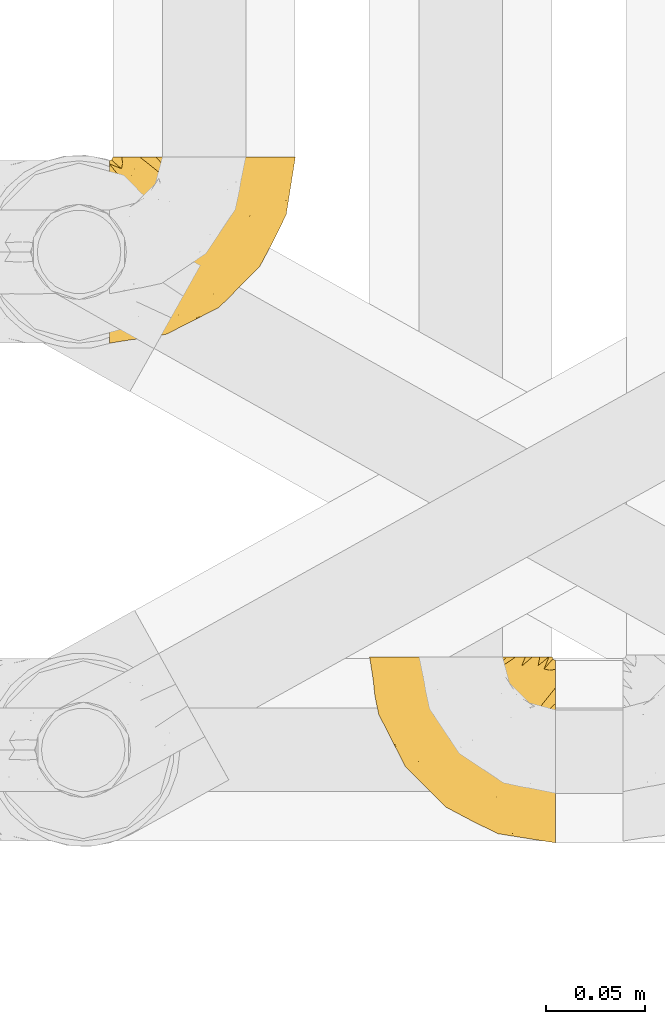
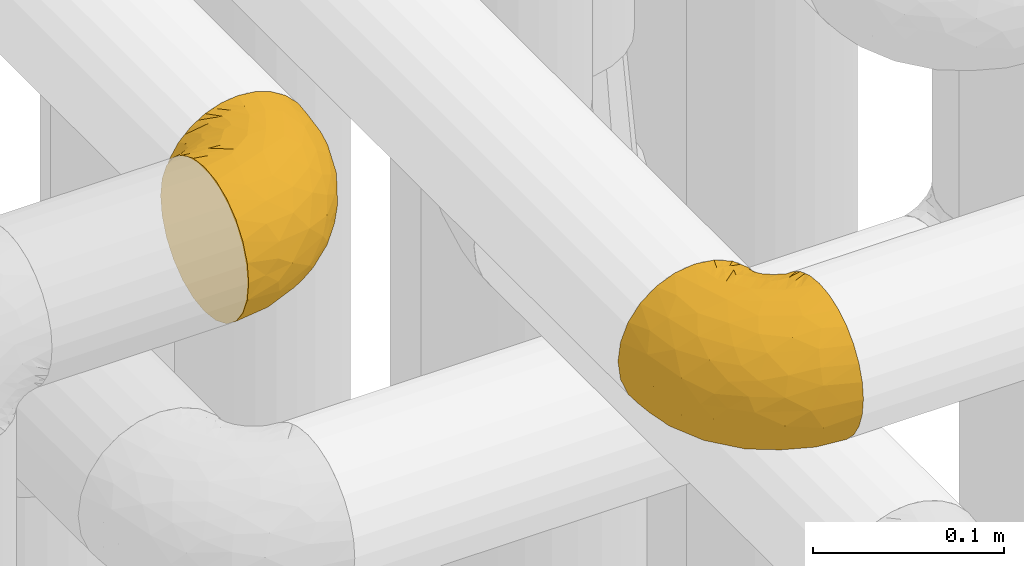
# One storey, part 154 of 827: 2 coverings.
"""IFC2X3 building model written with IfcOpenShell, lengths in millimetres."""

from ifc_helpers import new_model, entity, si_unit, converted_unit, derived_unit, direction, frame, origin, place, context, subcontext, project, spatial, faceted_brep, element, save


model = new_model("IFC2X3")

# Units and contexts
model_context = context("Model", 3, precision=0.01, world=origin(), true_north=direction((6.12303176911189e-17, 1.0)))
body_context = subcontext(model_context, "Body", "Model", "MODEL_VIEW")
ifc_project = project(units=[si_unit("LENGTHUNIT", "METRE", prefix="MILLI"), si_unit("AREAUNIT", "SQUARE_METRE"), si_unit("VOLUMEUNIT", "CUBIC_METRE"), converted_unit("PLANEANGLEUNIT", "DEGREE", entity("IfcRatioMeasure", 0.0174532925199433), si_unit("PLANEANGLEUNIT", "RADIAN"), dimensions=[0, 0, 0, 0, 0, 0, 0]), si_unit("MASSUNIT", "GRAM", prefix="KILO"), derived_unit("MASSDENSITYUNIT", [(si_unit("MASSUNIT", "GRAM", prefix="KILO"), 1), (si_unit("LENGTHUNIT", "METRE"), -3)]), derived_unit("MOMENTOFINERTIAUNIT", [(si_unit("LENGTHUNIT", "METRE"), 4)]), si_unit("TIMEUNIT", "SECOND"), si_unit("FREQUENCYUNIT", "HERTZ"), si_unit("THERMODYNAMICTEMPERATUREUNIT", "DEGREE_CELSIUS"), derived_unit("THERMALTRANSMITTANCEUNIT", [(si_unit("MASSUNIT", "GRAM", prefix="KILO"), 1), (si_unit("THERMODYNAMICTEMPERATUREUNIT", "KELVIN"), -1), (si_unit("TIMEUNIT", "SECOND"), -3)]), derived_unit("VOLUMETRICFLOWRATEUNIT", [(si_unit("LENGTHUNIT", "METRE"), 3), (si_unit("TIMEUNIT", "SECOND"), -1)]), derived_unit("MASSFLOWRATEUNIT", [(si_unit("MASSUNIT", "GRAM", prefix="KILO"), 1), (si_unit("TIMEUNIT", "SECOND"), -1)]), derived_unit("ROTATIONALFREQUENCYUNIT", [(si_unit("TIMEUNIT", "SECOND"), -1)]), si_unit("ELECTRICCURRENTUNIT", "AMPERE"), si_unit("ELECTRICVOLTAGEUNIT", "VOLT"), si_unit("POWERUNIT", "WATT"), si_unit("FORCEUNIT", "NEWTON", prefix="KILO"), si_unit("ILLUMINANCEUNIT", "LUX"), si_unit("LUMINOUSFLUXUNIT", "LUMEN"), si_unit("LUMINOUSINTENSITYUNIT", "CANDELA"), derived_unit("USERDEFINED", [(si_unit("MASSUNIT", "GRAM", prefix="KILO"), -1), (si_unit("LENGTHUNIT", "METRE"), -2), (si_unit("TIMEUNIT", "SECOND"), 3), (si_unit("LUMINOUSFLUXUNIT", "LUMEN"), 1)]), derived_unit("LINEARVELOCITYUNIT", [(si_unit("LENGTHUNIT", "METRE"), 1), (si_unit("TIMEUNIT", "SECOND"), -1)]), si_unit("PRESSUREUNIT", "PASCAL"), derived_unit("USERDEFINED", [(si_unit("LENGTHUNIT", "METRE"), -2), (si_unit("MASSUNIT", "GRAM", prefix="KILO"), 1), (si_unit("TIMEUNIT", "SECOND"), -2)]), derived_unit("LINEARFORCEUNIT", [(si_unit("MASSUNIT", "GRAM", prefix="KILO"), 1), (si_unit("LENGTHUNIT", "METRE"), 1), (si_unit("TIMEUNIT", "SECOND"), -2), (si_unit("LENGTHUNIT", "METRE"), -1)]), derived_unit("PLANARFORCEUNIT", [(si_unit("MASSUNIT", "GRAM", prefix="KILO"), 1), (si_unit("LENGTHUNIT", "METRE"), 1), (si_unit("TIMEUNIT", "SECOND"), -2), (si_unit("LENGTHUNIT", "METRE"), -2)])], contexts=[model_context])

# Site, building, storey
site_placement = place(None, origin())
site = spatial("IfcSite", under=ifc_project, at=site_placement, CompositionType="ELEMENT")
building_placement = place(site_placement, origin())
building = spatial("IfcBuilding", under=site, at=building_placement, CompositionType="ELEMENT")
storey_placement = place(building_placement, frame((0.0, 0.0, 28200.0)))
storey = spatial("IfcBuildingStorey", under=building, at=storey_placement, Name="08", CompositionType="ELEMENT", Elevation=28200.0)

# Coverings
covering_1_placement = place(storey_placement, frame((35290.44, 10561.35, 3352.2)))
element("IfcCovering", 1, at=covering_1_placement, inside=storey, Name=":ADSK_", ObjectType=":ADSK_", PredefinedType="INSULATION", context=body_context, shape_type="Brep", body=[
    faceted_brep([(78.41, 95.8, 83.91), (85.72, 95.8, 76.59), (91.22, 95.8, 67.83), (94.64, 95.8, 58.07), (95.8, 95.8, 47.8), (94.64, 95.8, 37.51), (91.22, 95.8, 27.74), (85.71, 95.8, 18.98), (78.39, 95.8, 11.67), (69.63, 95.8, 6.17), (59.87, 95.8, 2.75), (49.6, 95.8, 1.6), (45.45, 95.8, 2.06), (42.38, 95.8, 2.41), (39.31, 95.8, 2.75), (34.43, 95.8, 4.46), (29.54, 95.8, 6.17), (25.16, 95.8, 8.93), (20.78, 95.8, 11.68), (17.13, 95.8, 15.34), (13.47, 95.8, 19.0), (7.97, 95.8, 27.76), (6.26, 95.8, 32.64), (4.55, 95.8, 37.52), (3.4, 95.8, 47.8), (4.55, 95.8, 58.08), (6.26, 95.8, 62.96), (7.97, 95.8, 67.85), (13.48, 95.8, 76.61), (17.14, 95.8, 80.26), (20.8, 95.8, 83.92), (25.18, 95.8, 86.67), (29.56, 95.8, 89.42), (34.44, 95.8, 91.13), (39.32, 95.8, 92.84), (42.39, 95.8, 93.18), (45.45, 95.8, 93.53), (49.6, 95.8, 94.0), (59.88, 95.8, 92.84), (69.65, 95.8, 89.42), (1.6, 94.0, 47.8), (1.6, 92.42, 35.84), (1.6, 87.81, 24.7), (1.6, 84.13, 19.91), (1.6, 80.46, 15.13), (1.6, 75.68, 11.46), (1.6, 70.9, 7.78), (1.6, 65.32, 5.48), (1.6, 59.75, 3.17), (1.6, 56.14, 2.69), (1.6, 54.06, 2.42), (1.6, 51.97, 2.14), (1.6, 47.8, 1.6), (1.6, 35.84, 3.17), (1.6, 24.7, 7.78), (1.6, 15.13, 15.13), (1.6, 7.78, 24.7), (1.6, 3.17, 35.84), (1.6, 1.6, 47.8), (1.6, 3.17, 59.75), (1.6, 7.78, 70.9), (1.6, 15.13, 80.46), (1.6, 24.7, 87.81), (1.6, 35.84, 92.42), (1.6, 47.8, 94.0), (1.6, 51.97, 93.45), (1.6, 56.14, 92.9), (1.6, 59.75, 92.42), (1.6, 65.32, 90.11), (1.6, 70.9, 87.81), (1.6, 75.68, 84.13), (1.6, 80.46, 80.46), (1.6, 84.13, 75.68), (1.6, 87.81, 70.9), (1.6, 92.42, 59.75), (36.81, 15.84, 71.98), (23.28, 6.99, 63.6), (45.8, 14.39, 59.72), (30.7, 6.21, 47.8), (21.2, 4.26, 55.16), (12.96, 3.39, 47.8), (66.19, 31.2, 63.76), (54.51, 26.47, 72.22), (17.98, 11.44, 74.18), (36.69, 47.66, 92.52), (35.54, 61.85, 94.0), (31.64, 59.25, 94.0), (27.75, 56.65, 94.0), (23.86, 54.05, 94.0), (19.96, 51.45, 94.0), (22.8, 19.8, 82.14), (42.67, 26.22, 80.34), (33.21, 31.58, 87.52), (59.45, 38.36, 79.59), (71.5, 51.54, 78.25), (62.66, 51.6, 85.01), (54.5, 55.97, 90.25), (47.57, 62.88, 93.2), (48.81, 41.35, 87.23), (74.98, 82.24, 85.55), (18.7, 40.88, 93.0), (15.75, 29.0, 89.31), (91.17, 74.06, 61.31), (85.28, 54.53, 56.86), (82.58, 57.98, 68.34), (75.78, 43.81, 65.71), (74.98, 38.22, 56.99), (67.27, 38.33, 72.15), (87.38, 74.76, 70.34), (82.04, 76.85, 78.36), (94.0, 84.43, 47.8), (77.8, 40.43, 47.8), (67.38, 30.01, 47.8), (56.2, 78.67, 93.06), (48.85, 92.06, 94.0), (48.11, 88.32, 94.0), (47.57, 85.6, 94.0), (47.03, 82.88, 94.0), (46.48, 80.15, 94.0), (45.94, 77.43, 94.0), (65.78, 76.36, 89.88), (17.24, 50.91, 94.0), (14.51, 50.37, 94.0), (11.79, 49.82, 94.0), (9.07, 49.28, 94.0), (7.2, 48.91, 94.0), (5.33, 48.54, 94.0), (91.18, 66.69, 47.8), (43.34, 73.53, 94.0), (40.74, 69.64, 94.0), (38.14, 65.75, 94.0), (72.73, 66.13, 83.7), (56.96, 19.59, 47.8), (62.23, 24.64, 55.9), (84.49, 53.56, 47.8), (43.83, 12.9, 47.8), (12.05, 82.81, 81.75), (18.95, 81.22, 86.43), (13.02, 86.57, 79.8), (8.34, 92.75, 69.84), (14.63, 89.68, 79.5), (11.09, 72.26, 88.08), (13.66, 64.73, 91.6), (20.08, 62.45, 92.93), (9.61, 60.63, 92.43), (9.48, 56.91, 93.24), (16.1, 58.14, 93.36), (3.42, 93.7, 57.25), (26.63, 83.4, 89.41), (33.72, 75.54, 92.89), (34.77, 79.46, 92.66), (6.75, 82.28, 79.58), (13.31, 76.25, 86.51), (21.11, 84.69, 86.29), (19.94, 90.18, 83.91), (6.04, 86.94, 73.94), (8.67, 65.12, 90.94), (26.11, 71.71, 91.94), (29.3, 75.21, 91.98), (6.32, 78.6, 82.79), (39.92, 87.27, 93.16), (27.05, 87.92, 88.76), (34.4, 86.1, 91.89), (2.87, 94.52, 47.8), (20.92, 66.23, 92.22), (27.43, 91.08, 88.56), (7.54, 71.77, 87.72), (18.45, 76.21, 88.33), (23.88, 68.59, 92.18), (7.77, 89.94, 71.78), (13.3, 76.25, 9.09), (11.09, 72.26, 7.51), (6.33, 78.6, 12.8), (9.07, 49.28, 1.6), (5.33, 48.54, 1.6), (14.51, 50.37, 1.6), (11.79, 49.82, 1.6), (3.42, 93.7, 38.35), (7.76, 89.95, 23.84), (47.03, 82.88, 1.6), (47.57, 85.6, 1.6), (48.85, 92.06, 1.6), (48.11, 88.32, 1.6), (14.62, 89.68, 16.1), (27.03, 87.92, 6.84), (20.08, 62.45, 2.66), (20.92, 66.24, 3.37), (27.75, 56.65, 1.6), (31.64, 59.25, 1.6), (9.61, 60.63, 3.16), (9.48, 56.91, 2.35), (8.33, 92.76, 25.77), (6.74, 82.28, 16.02), (12.04, 82.81, 13.85), (23.86, 54.05, 1.6), (19.96, 51.45, 1.6), (16.1, 58.14, 2.23), (19.93, 90.18, 11.69), (21.1, 84.7, 9.31), (39.92, 87.25, 2.43), (33.68, 75.58, 2.71), (29.28, 75.2, 3.61), (26.62, 83.39, 6.18), (26.08, 71.7, 3.66), (18.93, 81.22, 9.17), (27.87, 90.73, 6.77), (34.75, 79.47, 2.93), (6.04, 86.94, 21.66), (38.14, 65.75, 1.6), (12.79, 86.75, 16.09), (34.41, 86.08, 3.7), (45.94, 77.43, 1.6), (43.34, 73.53, 1.6), (40.74, 69.64, 1.6), (13.66, 64.73, 3.99), (17.24, 50.91, 1.6), (8.67, 65.12, 4.65), (35.54, 61.85, 1.6), (23.83, 68.62, 3.43), (18.43, 76.22, 7.27), (6.03, 74.03, 9.46), (46.48, 80.15, 1.6), (34.52, 49.81, 2.4), (21.2, 4.26, 40.43), (23.82, 19.95, 13.57), (41.32, 30.61, 11.3), (47.62, 25.71, 18.65), (52.66, 22.43, 27.26), (36.81, 15.85, 23.61), (49.75, 60.69, 3.07), (19.07, 40.49, 2.69), (45.8, 14.39, 35.87), (23.28, 6.99, 31.99), (21.35, 29.56, 6.71), (17.98, 11.45, 21.41), (82.57, 57.98, 27.24), (91.17, 74.06, 34.26), (85.27, 54.52, 38.73), (73.89, 43.47, 26.97), (66.19, 31.2, 31.83), (62.43, 33.27, 23.4), (63.53, 64.26, 6.91), (58.45, 74.29, 3.4), (67.16, 80.41, 5.84), (62.22, 24.64, 39.69), (81.54, 73.62, 17.6), (74.8, 78.98, 10.38), (75.83, 53.69, 20.6), (41.45, 42.86, 5.36), (76.72, 41.67, 35.73), (88.2, 79.66, 24.84), (71.6, 58.41, 13.87), (56.23, 47.11, 9.06), (59.44, 38.37, 15.99)], [[[0, 1, 2, 3, 4, 5, 6, 7, 8, 9, 10, 11, 12, 13, 14, 15, 16, 17, 18, 19, 20, 21, 22, 23, 24, 25, 26, 27, 28, 29, 30, 31, 32, 33, 34, 35, 36, 37, 38, 39]], [[40, 41, 42, 43, 44, 45, 46, 47, 48, 49, 50, 51, 52, 53, 54, 55, 56, 57, 58, 59, 60, 61, 62, 63, 64, 65, 66, 67, 68, 69, 70, 71, 72, 73, 74]], [[75, 76, 77]], [[78, 79, 80]], [[77, 81, 82]], [[76, 75, 83]], [[84, 85, 86, 87, 88, 89]], [[90, 91, 92]], [[76, 60, 59]], [[93, 94, 95]], [[90, 62, 61]], [[83, 61, 60]], [[96, 97, 84]], [[98, 93, 95]], [[0, 39, 99]], [[100, 84, 89]], [[62, 101, 63]], [[2, 102, 3]], [[92, 84, 100]], [[103, 102, 104]], [[103, 105, 106]], [[93, 107, 94]], [[1, 108, 2]], [[92, 101, 90]], [[108, 1, 109]], [[102, 110, 3]], [[93, 82, 107]], [[102, 108, 104]], [[111, 106, 112]], [[109, 0, 99]], [[113, 37, 114, 115, 116, 117, 118, 119]], [[120, 38, 113]], [[100, 89, 121, 122, 123, 124, 125, 126, 64]], [[127, 102, 103]], [[97, 119, 128, 129, 130, 85]], [[99, 120, 131]], [[132, 133, 77]], [[59, 80, 79]], [[1, 0, 109]], [[98, 84, 92]], [[94, 109, 131]], [[120, 39, 38]], [[93, 91, 82]], [[104, 94, 105]], [[97, 113, 119]], [[95, 120, 96]], [[83, 90, 61]], [[91, 93, 98]], [[64, 63, 100]], [[100, 63, 101]], [[77, 76, 79]], [[133, 106, 81]], [[84, 97, 85]], [[113, 96, 120]], [[113, 97, 96]], [[37, 113, 38]], [[110, 102, 127]], [[110, 4, 3]], [[103, 111, 134, 127]], [[90, 75, 91]], [[82, 81, 107]], [[91, 75, 82]], [[77, 82, 75]], [[76, 83, 60]], [[90, 83, 75]], [[105, 107, 81]], [[94, 131, 95]], [[105, 94, 107]], [[109, 94, 104]], [[120, 95, 131]], [[98, 95, 96]], [[84, 98, 96]], [[98, 92, 91]], [[106, 105, 81]], [[103, 104, 105]], [[112, 106, 133]], [[103, 106, 111]], [[112, 133, 132]], [[81, 77, 133]], [[77, 78, 135, 132]], [[120, 99, 39]], [[109, 99, 131]], [[59, 58, 80]], [[59, 79, 76]], [[90, 101, 62]], [[100, 101, 92]], [[2, 108, 102]], [[109, 104, 108]], [[78, 77, 79]], [[136, 137, 138]], [[27, 139, 140]], [[141, 142, 143]], [[144, 145, 121]], [[146, 89, 88]], [[147, 139, 25]], [[148, 149, 150]], [[136, 151, 152]], [[147, 40, 74]], [[24, 147, 25]], [[140, 153, 154]], [[33, 116, 34]], [[73, 151, 155]], [[114, 37, 36, 35, 34, 116, 115]], [[146, 156, 144]], [[157, 85, 130]], [[158, 149, 148]], [[151, 159, 152]], [[117, 33, 160]], [[29, 154, 161]], [[155, 74, 73]], [[162, 128, 119]], [[66, 65, 64, 126, 125, 124, 123, 122, 67]], [[163, 147, 24]], [[27, 140, 28]], [[149, 129, 150]], [[139, 27, 26, 25]], [[68, 144, 69]], [[129, 128, 150]], [[164, 87, 86]], [[130, 129, 149]], [[122, 145, 67]], [[154, 153, 148]], [[162, 119, 160]], [[165, 30, 161]], [[150, 161, 148]], [[128, 162, 150]], [[30, 165, 31]], [[145, 144, 68]], [[89, 146, 144]], [[87, 164, 143]], [[166, 156, 142]], [[88, 87, 143]], [[162, 161, 150]], [[161, 30, 29]], [[154, 29, 28]], [[140, 154, 28]], [[161, 154, 148]], [[140, 137, 153]], [[158, 148, 153]], [[157, 130, 158]], [[153, 137, 158]], [[158, 137, 157]], [[167, 137, 136]], [[168, 85, 157]], [[152, 168, 167]], [[167, 168, 157]], [[164, 152, 141]], [[151, 73, 72]], [[159, 72, 71]], [[88, 142, 146]], [[144, 156, 69]], [[146, 142, 156]], [[70, 166, 71]], [[142, 141, 166]], [[70, 69, 156]], [[141, 159, 71]], [[167, 136, 152]], [[138, 137, 140]], [[155, 136, 169]], [[136, 155, 151]], [[74, 155, 169]], [[152, 159, 141]], [[151, 72, 159]], [[168, 152, 164]], [[137, 167, 157]], [[164, 86, 168]], [[85, 168, 86]], [[116, 33, 117]], [[130, 149, 158]], [[67, 145, 68]], [[121, 89, 144]], [[145, 122, 121]], [[40, 147, 163]], [[169, 147, 74]], [[160, 33, 32]], [[162, 160, 32]], [[160, 119, 118, 117]], [[139, 147, 169]], [[139, 169, 138]], [[162, 32, 31]], [[141, 143, 164]], [[88, 143, 142]], [[71, 166, 141]], [[156, 166, 70]], [[139, 138, 140]], [[169, 136, 138]], [[161, 162, 165]], [[162, 31, 165]], [[170, 171, 172]], [[173, 174, 52, 51, 50, 49, 48, 175, 176]], [[177, 178, 41]], [[179, 15, 180]], [[12, 11, 181, 182, 180, 14, 13]], [[183, 21, 20]], [[19, 18, 184]], [[185, 186, 187]], [[186, 188, 187]], [[43, 172, 44]], [[189, 190, 47]], [[23, 22, 21, 191]], [[170, 192, 193]], [[40, 163, 177]], [[194, 195, 196]], [[24, 23, 177]], [[197, 198, 183]], [[199, 15, 179]], [[178, 177, 191]], [[47, 46, 189]], [[200, 201, 202]], [[201, 203, 204]], [[205, 206, 184]], [[207, 41, 178]], [[16, 15, 199]], [[14, 180, 15]], [[202, 201, 198]], [[208, 201, 200]], [[163, 24, 177]], [[48, 47, 190]], [[196, 195, 189]], [[197, 184, 202]], [[204, 193, 209]], [[210, 211, 212]], [[206, 212, 213]], [[205, 17, 210]], [[184, 206, 202]], [[210, 212, 206]], [[185, 194, 214]], [[189, 215, 190]], [[216, 45, 214]], [[186, 171, 170]], [[189, 216, 196]], [[197, 20, 19]], [[194, 185, 187]], [[197, 183, 20]], [[184, 197, 19]], [[197, 202, 198]], [[206, 200, 202]], [[204, 183, 198]], [[201, 208, 203]], [[203, 208, 217]], [[204, 198, 201]], [[217, 188, 218]], [[193, 219, 170]], [[171, 186, 185]], [[170, 218, 186]], [[170, 219, 218]], [[42, 207, 192]], [[171, 220, 172]], [[216, 189, 46]], [[214, 194, 196]], [[44, 220, 45]], [[214, 196, 216]], [[216, 46, 45]], [[214, 45, 220]], [[192, 43, 42]], [[204, 203, 219]], [[207, 193, 192]], [[209, 193, 178]], [[41, 207, 42]], [[193, 207, 178]], [[43, 192, 172]], [[170, 172, 192]], [[204, 219, 193]], [[219, 203, 218]], [[217, 218, 203]], [[188, 186, 218]], [[206, 213, 200]], [[208, 200, 213]], [[199, 210, 16]], [[215, 189, 195]], [[215, 175, 190]], [[175, 48, 190]], [[199, 179, 221, 211]], [[210, 199, 211]], [[23, 191, 177]], [[40, 177, 41]], [[191, 183, 209]], [[21, 183, 191]], [[205, 18, 17]], [[17, 16, 210]], [[171, 185, 214]], [[172, 220, 44]], [[214, 220, 171]], [[191, 209, 178]], [[204, 209, 183]], [[206, 205, 210]], [[18, 205, 184]], [[222, 195, 194, 187, 188, 217]], [[57, 223, 80]], [[224, 225, 226]], [[226, 227, 228]], [[229, 217, 208, 213, 212, 211]], [[230, 52, 174, 173, 176, 175, 215, 195]], [[231, 232, 228]], [[231, 78, 223]], [[223, 57, 232]], [[224, 233, 225]], [[233, 54, 53]], [[234, 232, 56]], [[56, 55, 234]], [[234, 224, 228]], [[235, 236, 237]], [[224, 55, 54]], [[238, 239, 240]], [[52, 230, 53]], [[241, 242, 243]], [[231, 227, 244]], [[11, 10, 242]], [[236, 6, 5]], [[7, 245, 8]], [[8, 246, 9]], [[238, 247, 235]], [[222, 229, 248]], [[242, 211, 221, 179, 180, 182, 181, 11]], [[233, 53, 230]], [[111, 112, 249]], [[250, 6, 236]], [[246, 251, 241]], [[6, 250, 7]], [[127, 236, 110]], [[248, 229, 252]], [[246, 8, 245]], [[235, 245, 250]], [[236, 5, 110]], [[235, 249, 238]], [[237, 236, 127]], [[243, 9, 246]], [[252, 229, 241]], [[56, 232, 57]], [[222, 230, 195]], [[225, 248, 252]], [[248, 233, 230]], [[54, 233, 224]], [[231, 228, 227]], [[244, 132, 231]], [[248, 225, 233]], [[226, 225, 253]], [[235, 250, 236]], [[245, 7, 250]], [[251, 246, 245]], [[243, 246, 241]], [[247, 245, 235]], [[252, 251, 253]], [[229, 222, 217]], [[230, 222, 248]], [[5, 4, 110]], [[237, 127, 134, 111]], [[238, 249, 239]], [[224, 234, 55]], [[232, 234, 228]], [[242, 241, 229]], [[10, 9, 243]], [[211, 242, 229]], [[10, 243, 242]], [[80, 223, 78]], [[80, 58, 57]], [[231, 223, 232]], [[227, 240, 239]], [[224, 226, 228]], [[240, 226, 253]], [[227, 239, 244]], [[226, 240, 227]], [[251, 247, 253]], [[240, 253, 247]], [[249, 235, 237]], [[237, 111, 249]], [[244, 239, 249]], [[112, 244, 249]], [[135, 78, 231, 132]], [[112, 132, 244]], [[247, 238, 240]], [[245, 247, 251]], [[251, 252, 241]], [[225, 252, 253]]]),
])
covering_2_placement = place(storey_placement, frame((35422.24, 10308.37, 3352.2)))
element("IfcCovering", 2, at=covering_2_placement, inside=storey, Name=":ADSK_", ObjectType=":ADSK_", PredefinedType="INSULATION", context=body_context, shape_type="Brep", body=[
    faceted_brep([(95.8, 37.51, 92.84), (95.8, 27.74, 89.42), (95.8, 18.98, 83.91), (95.8, 11.67, 76.59), (95.8, 6.17, 67.83), (95.8, 2.75, 58.07), (95.8, 1.6, 47.8), (95.8, 2.75, 37.51), (95.8, 6.17, 27.74), (95.8, 11.68, 18.98), (95.8, 19.0, 11.67), (95.8, 27.76, 6.17), (95.8, 37.52, 2.75), (95.8, 47.8, 1.6), (95.8, 51.94, 2.06), (95.8, 55.01, 2.41), (95.8, 58.08, 2.75), (95.8, 62.96, 4.46), (95.8, 67.85, 6.17), (95.8, 72.23, 8.93), (95.8, 76.61, 11.68), (95.8, 80.26, 15.34), (95.8, 83.92, 19.0), (95.8, 89.42, 27.76), (95.8, 91.13, 32.64), (95.8, 92.84, 37.52), (95.8, 94.0, 47.8), (95.8, 92.84, 58.08), (95.8, 91.13, 62.96), (95.8, 89.42, 67.85), (95.8, 83.91, 76.61), (95.8, 80.25, 80.26), (95.8, 76.59, 83.92), (95.8, 72.21, 86.67), (95.8, 67.83, 89.42), (95.8, 62.95, 91.13), (95.8, 58.07, 92.84), (95.8, 55.0, 93.18), (95.8, 51.94, 93.53), (95.8, 47.8, 94.0), (94.0, 95.8, 47.8), (92.42, 95.8, 35.84), (87.81, 95.8, 24.7), (84.13, 95.8, 19.91), (80.46, 95.8, 15.13), (75.68, 95.8, 11.46), (70.9, 95.8, 7.78), (65.32, 95.8, 5.48), (59.75, 95.8, 3.17), (56.14, 95.8, 2.69), (54.06, 95.8, 2.42), (51.97, 95.8, 2.14), (47.8, 95.8, 1.6), (35.84, 95.8, 3.17), (24.7, 95.8, 7.78), (15.13, 95.8, 15.13), (7.78, 95.8, 24.7), (3.17, 95.8, 35.84), (1.6, 95.8, 47.8), (3.17, 95.8, 59.75), (7.78, 95.8, 70.9), (15.13, 95.8, 80.46), (24.7, 95.8, 87.81), (35.84, 95.8, 92.42), (47.8, 95.8, 94.0), (51.97, 95.8, 93.45), (56.14, 95.8, 92.9), (59.75, 95.8, 92.42), (65.32, 95.8, 90.11), (70.9, 95.8, 87.81), (75.68, 95.8, 84.13), (80.46, 95.8, 80.46), (84.13, 95.8, 75.68), (87.81, 95.8, 70.9), (92.42, 95.8, 59.75), (15.84, 60.58, 71.98), (6.99, 74.11, 63.6), (14.39, 51.59, 59.72), (6.21, 66.69, 47.8), (4.26, 76.19, 55.16), (3.39, 84.43, 47.8), (31.2, 31.2, 63.76), (26.47, 42.88, 72.22), (11.44, 79.41, 74.18), (47.66, 60.7, 92.52), (61.85, 61.85, 94.0), (59.25, 65.75, 94.0), (56.65, 69.64, 94.0), (54.05, 73.53, 94.0), (51.45, 77.43, 94.0), (19.8, 74.59, 82.14), (26.22, 54.72, 80.34), (31.58, 64.18, 87.52), (38.36, 37.94, 79.59), (51.54, 25.89, 78.25), (51.6, 34.73, 85.01), (55.97, 42.89, 90.25), (62.88, 49.83, 93.2), (41.35, 48.58, 87.23), (82.24, 22.41, 85.55), (40.88, 78.69, 93.0), (29.0, 81.64, 89.31), (74.06, 6.22, 61.31), (54.53, 12.11, 56.86), (57.98, 14.81, 68.34), (43.81, 21.61, 65.71), (38.22, 22.41, 56.99), (38.33, 30.12, 72.15), (74.76, 10.01, 70.34), (76.85, 15.36, 78.36), (84.43, 3.39, 47.8), (40.43, 19.59, 47.8), (30.01, 30.01, 47.8), (78.67, 41.19, 93.06), (92.06, 48.54, 94.0), (88.32, 49.28, 94.0), (85.6, 49.82, 94.0), (82.88, 50.37, 94.0), (80.15, 50.91, 94.0), (77.43, 51.45, 94.0), (76.36, 31.61, 89.88), (50.91, 80.15, 94.0), (50.37, 82.88, 94.0), (49.82, 85.6, 94.0), (49.28, 88.32, 94.0), (48.91, 90.19, 94.0), (48.54, 92.06, 94.0), (66.69, 6.21, 47.8), (73.53, 54.05, 94.0), (69.64, 56.65, 94.0), (65.75, 59.25, 94.0), (66.13, 24.66, 83.7), (19.59, 40.43, 47.8), (24.64, 35.17, 55.9), (53.56, 12.9, 47.8), (12.9, 53.56, 47.8), (82.81, 85.34, 81.75), (81.22, 78.44, 86.43), (86.57, 84.37, 79.8), (92.75, 89.05, 69.84), (89.68, 82.76, 79.5), (72.26, 86.31, 88.08), (64.73, 83.73, 91.6), (62.45, 77.31, 92.93), (60.63, 87.78, 92.43), (56.91, 87.91, 93.24), (58.14, 81.29, 93.36), (93.7, 93.97, 57.25), (83.4, 70.76, 89.41), (75.54, 63.67, 92.89), (79.46, 62.62, 92.66), (82.28, 90.64, 79.58), (76.25, 84.08, 86.51), (84.69, 76.28, 86.29), (90.18, 77.45, 83.91), (65.12, 88.72, 90.94), (71.71, 71.28, 91.94), (75.21, 68.09, 91.98), (78.6, 91.07, 82.79), (87.27, 57.47, 93.16), (87.92, 70.34, 88.76), (86.94, 91.35, 73.94), (86.1, 62.99, 91.89), (94.52, 94.52, 47.8), (66.23, 76.47, 92.22), (91.08, 69.96, 88.56), (71.77, 89.86, 87.72), (76.21, 78.94, 88.33), (68.59, 73.51, 92.18), (89.94, 89.62, 71.78), (76.25, 84.09, 9.09), (72.26, 86.3, 7.51), (78.6, 91.06, 12.8), (49.28, 88.32, 1.6), (48.54, 92.06, 1.6), (50.37, 82.88, 1.6), (49.82, 85.6, 1.6), (93.7, 93.97, 38.35), (89.95, 89.63, 23.84), (82.88, 50.37, 1.6), (85.6, 49.82, 1.6), (92.06, 48.54, 1.6), (88.32, 49.28, 1.6), (89.68, 82.77, 16.1), (87.92, 70.36, 6.84), (62.45, 77.31, 2.66), (66.24, 76.47, 3.37), (56.65, 69.64, 1.6), (59.25, 65.75, 1.6), (60.63, 87.78, 3.16), (56.91, 87.91, 2.35), (92.76, 89.06, 25.77), (82.28, 90.65, 16.02), (82.81, 85.35, 13.85), (54.05, 73.53, 1.6), (51.45, 77.43, 1.6), (58.14, 81.29, 2.23), (90.18, 77.46, 11.69), (84.7, 76.29, 9.31), (87.25, 57.47, 2.43), (75.58, 63.71, 2.71), (75.2, 68.11, 3.61), (83.39, 70.77, 6.18), (71.7, 71.31, 3.66), (81.22, 78.46, 9.17), (90.73, 69.52, 6.77), (79.47, 62.64, 2.93), (86.94, 91.35, 21.66), (65.75, 59.25, 1.6), (86.75, 84.6, 16.09), (86.08, 62.98, 3.7), (77.43, 51.45, 1.6), (73.53, 54.05, 1.6), (69.64, 56.65, 1.6), (64.73, 83.73, 3.99), (50.91, 80.15, 1.6), (65.12, 88.72, 4.65), (61.85, 61.85, 1.6), (68.62, 73.56, 3.43), (76.22, 78.96, 7.27), (74.03, 91.36, 9.46), (80.15, 50.91, 1.6), (49.81, 62.87, 2.4), (4.26, 76.19, 40.43), (19.95, 73.57, 13.57), (30.61, 56.07, 11.3), (25.71, 49.77, 18.65), (22.43, 44.73, 27.26), (15.85, 60.58, 23.61), (60.69, 47.64, 3.07), (40.49, 78.32, 2.69), (14.39, 51.59, 35.87), (6.99, 74.11, 31.99), (29.56, 76.04, 6.71), (11.45, 79.41, 21.41), (57.98, 14.82, 27.24), (74.06, 6.22, 34.26), (54.52, 12.12, 38.73), (43.47, 23.51, 26.97), (31.2, 31.2, 31.83), (33.27, 34.96, 23.4), (64.26, 33.86, 6.91), (74.29, 38.94, 3.4), (80.41, 30.23, 5.84), (41.67, 20.67, 35.73), (24.64, 35.17, 39.69), (73.62, 15.85, 17.6), (78.98, 22.59, 10.38), (53.69, 21.56, 20.6), (42.86, 55.94, 5.36), (79.66, 9.19, 24.84), (58.41, 25.79, 13.87), (47.11, 41.16, 9.06), (38.37, 37.95, 15.99)], [[[0, 1, 2, 3, 4, 5, 6, 7, 8, 9, 10, 11, 12, 13, 14, 15, 16, 17, 18, 19, 20, 21, 22, 23, 24, 25, 26, 27, 28, 29, 30, 31, 32, 33, 34, 35, 36, 37, 38, 39]], [[40, 41, 42, 43, 44, 45, 46, 47, 48, 49, 50, 51, 52, 53, 54, 55, 56, 57, 58, 59, 60, 61, 62, 63, 64, 65, 66, 67, 68, 69, 70, 71, 72, 73, 74]], [[75, 76, 77]], [[78, 79, 80]], [[77, 81, 82]], [[76, 75, 83]], [[84, 85, 86, 87, 88, 89]], [[90, 91, 92]], [[76, 60, 59]], [[93, 94, 95]], [[90, 62, 61]], [[83, 61, 60]], [[96, 97, 84]], [[98, 93, 95]], [[2, 1, 99]], [[100, 84, 89]], [[62, 101, 63]], [[4, 102, 5]], [[92, 84, 100]], [[103, 102, 104]], [[103, 105, 106]], [[93, 107, 94]], [[3, 108, 4]], [[92, 101, 90]], [[108, 3, 109]], [[102, 110, 5]], [[93, 82, 107]], [[102, 108, 104]], [[111, 106, 112]], [[109, 2, 99]], [[113, 39, 114, 115, 116, 117, 118, 119]], [[120, 0, 113]], [[100, 89, 121, 122, 123, 124, 125, 126, 64]], [[127, 102, 103]], [[97, 119, 128, 129, 130, 85]], [[99, 120, 131]], [[132, 133, 77]], [[59, 80, 79]], [[3, 2, 109]], [[98, 84, 92]], [[94, 109, 131]], [[120, 1, 0]], [[93, 91, 82]], [[104, 94, 105]], [[97, 113, 119]], [[95, 120, 96]], [[83, 90, 61]], [[91, 93, 98]], [[64, 63, 100]], [[100, 63, 101]], [[77, 76, 79]], [[133, 106, 81]], [[84, 97, 85]], [[113, 96, 120]], [[113, 97, 96]], [[39, 113, 0]], [[110, 102, 127]], [[110, 6, 5]], [[103, 111, 134, 127]], [[90, 75, 91]], [[82, 81, 107]], [[91, 75, 82]], [[77, 82, 75]], [[76, 83, 60]], [[90, 83, 75]], [[105, 107, 81]], [[94, 131, 95]], [[105, 94, 107]], [[109, 94, 104]], [[120, 95, 131]], [[98, 95, 96]], [[84, 98, 96]], [[98, 92, 91]], [[106, 105, 81]], [[103, 104, 105]], [[112, 106, 133]], [[103, 106, 111]], [[112, 133, 132]], [[81, 77, 133]], [[77, 78, 135, 132]], [[120, 99, 1]], [[109, 99, 131]], [[59, 58, 80]], [[59, 79, 76]], [[90, 101, 62]], [[100, 101, 92]], [[4, 108, 102]], [[109, 104, 108]], [[78, 77, 79]], [[136, 137, 138]], [[29, 139, 140]], [[141, 142, 143]], [[144, 145, 121]], [[146, 89, 88]], [[147, 139, 27]], [[148, 149, 150]], [[136, 151, 152]], [[147, 40, 74]], [[26, 147, 27]], [[140, 153, 154]], [[35, 116, 36]], [[73, 72, 151]], [[114, 39, 38, 37, 36, 116, 115]], [[146, 155, 144]], [[156, 85, 130]], [[157, 149, 148]], [[151, 158, 152]], [[117, 35, 159]], [[31, 154, 160]], [[161, 74, 73]], [[162, 128, 119]], [[66, 65, 64, 126, 125, 124, 123, 122, 67]], [[163, 147, 26]], [[29, 140, 30]], [[149, 129, 150]], [[139, 29, 28, 27]], [[68, 144, 69]], [[129, 128, 150]], [[164, 87, 86]], [[130, 129, 149]], [[122, 145, 67]], [[154, 153, 148]], [[162, 119, 159]], [[165, 32, 160]], [[150, 160, 148]], [[128, 162, 150]], [[32, 165, 33]], [[145, 144, 68]], [[89, 146, 144]], [[87, 164, 143]], [[166, 155, 142]], [[88, 87, 143]], [[162, 160, 150]], [[160, 32, 31]], [[154, 31, 30]], [[140, 154, 30]], [[160, 154, 148]], [[140, 137, 153]], [[157, 148, 153]], [[156, 130, 157]], [[153, 137, 157]], [[157, 137, 156]], [[167, 137, 136]], [[168, 85, 156]], [[152, 168, 167]], [[167, 168, 156]], [[164, 152, 141]], [[71, 158, 72]], [[152, 167, 136]], [[88, 142, 146]], [[144, 155, 69]], [[146, 142, 155]], [[70, 166, 71]], [[142, 141, 166]], [[70, 69, 155]], [[141, 158, 71]], [[161, 73, 151]], [[138, 137, 140]], [[161, 136, 169]], [[136, 161, 151]], [[74, 161, 169]], [[152, 158, 141]], [[151, 72, 158]], [[168, 152, 164]], [[137, 167, 156]], [[164, 86, 168]], [[85, 168, 86]], [[116, 35, 117]], [[130, 149, 157]], [[67, 145, 68]], [[121, 89, 144]], [[145, 122, 121]], [[40, 147, 163]], [[169, 147, 74]], [[159, 35, 34]], [[162, 159, 34]], [[159, 119, 118, 117]], [[139, 147, 169]], [[139, 169, 138]], [[162, 34, 33]], [[141, 143, 164]], [[88, 143, 142]], [[71, 166, 141]], [[155, 166, 70]], [[139, 138, 140]], [[169, 136, 138]], [[160, 162, 165]], [[162, 33, 165]], [[170, 171, 172]], [[173, 174, 52, 51, 50, 49, 48, 175, 176]], [[177, 178, 41]], [[179, 17, 180]], [[14, 13, 181, 182, 180, 16, 15]], [[183, 23, 22]], [[21, 20, 184]], [[185, 186, 187]], [[186, 188, 187]], [[43, 172, 44]], [[189, 190, 47]], [[25, 24, 23, 191]], [[170, 192, 193]], [[40, 163, 177]], [[194, 195, 196]], [[26, 25, 177]], [[197, 198, 183]], [[199, 17, 179]], [[47, 46, 189]], [[200, 201, 202]], [[201, 203, 204]], [[205, 206, 184]], [[207, 41, 178]], [[18, 17, 199]], [[16, 180, 17]], [[202, 201, 198]], [[208, 201, 200]], [[163, 26, 177]], [[48, 47, 190]], [[196, 195, 189]], [[197, 184, 202]], [[204, 193, 209]], [[210, 211, 212]], [[206, 212, 213]], [[205, 19, 210]], [[184, 206, 202]], [[210, 212, 206]], [[185, 194, 214]], [[189, 215, 190]], [[216, 45, 214]], [[186, 171, 170]], [[189, 216, 196]], [[197, 22, 21]], [[194, 185, 187]], [[197, 183, 22]], [[184, 197, 21]], [[197, 202, 198]], [[206, 200, 202]], [[204, 183, 198]], [[201, 208, 203]], [[203, 208, 217]], [[204, 198, 201]], [[217, 188, 218]], [[193, 219, 170]], [[171, 186, 185]], [[170, 218, 186]], [[170, 219, 218]], [[42, 207, 192]], [[171, 220, 172]], [[216, 189, 46]], [[214, 194, 196]], [[44, 220, 45]], [[214, 196, 216]], [[216, 46, 45]], [[214, 45, 220]], [[192, 43, 42]], [[204, 203, 219]], [[207, 193, 192]], [[209, 193, 178]], [[41, 207, 42]], [[193, 207, 178]], [[43, 192, 172]], [[170, 172, 192]], [[204, 219, 193]], [[219, 203, 218]], [[217, 218, 203]], [[188, 186, 218]], [[206, 213, 200]], [[208, 200, 213]], [[199, 210, 18]], [[215, 189, 195]], [[215, 175, 190]], [[175, 48, 190]], [[199, 179, 221, 211]], [[210, 199, 211]], [[25, 191, 177]], [[40, 177, 41]], [[183, 209, 191]], [[183, 191, 23]], [[191, 178, 177]], [[205, 20, 19]], [[19, 18, 210]], [[171, 185, 214]], [[172, 220, 44]], [[214, 220, 171]], [[191, 209, 178]], [[204, 209, 183]], [[206, 205, 210]], [[20, 205, 184]], [[222, 195, 194, 187, 188, 217]], [[57, 223, 80]], [[224, 225, 226]], [[226, 227, 228]], [[229, 217, 208, 213, 212, 211]], [[230, 52, 174, 173, 176, 175, 215, 195]], [[231, 232, 228]], [[231, 78, 223]], [[223, 57, 232]], [[224, 233, 225]], [[233, 54, 53]], [[234, 232, 56]], [[56, 55, 234]], [[234, 224, 228]], [[235, 236, 237]], [[224, 55, 54]], [[238, 239, 240]], [[52, 230, 53]], [[241, 242, 243]], [[239, 244, 245]], [[13, 12, 242]], [[236, 8, 7]], [[9, 246, 10]], [[10, 247, 11]], [[238, 248, 235]], [[222, 229, 249]], [[242, 211, 221, 179, 180, 182, 181, 13]], [[233, 53, 230]], [[111, 112, 244]], [[250, 8, 236]], [[247, 251, 241]], [[8, 250, 9]], [[127, 236, 110]], [[249, 229, 252]], [[247, 10, 246]], [[235, 246, 250]], [[236, 7, 110]], [[235, 244, 238]], [[237, 236, 127]], [[243, 11, 247]], [[252, 229, 241]], [[56, 232, 57]], [[222, 230, 195]], [[225, 249, 252]], [[249, 233, 230]], [[54, 233, 224]], [[231, 228, 227]], [[245, 132, 231]], [[249, 225, 233]], [[226, 225, 253]], [[235, 250, 236]], [[246, 9, 250]], [[251, 247, 246]], [[243, 247, 241]], [[248, 246, 235]], [[252, 251, 253]], [[229, 222, 217]], [[230, 222, 249]], [[7, 6, 110]], [[237, 127, 134, 111]], [[238, 244, 239]], [[224, 234, 55]], [[232, 234, 228]], [[242, 241, 229]], [[12, 11, 243]], [[211, 242, 229]], [[12, 243, 242]], [[80, 223, 78]], [[80, 58, 57]], [[231, 223, 232]], [[227, 240, 239]], [[224, 226, 228]], [[240, 226, 253]], [[227, 239, 245]], [[226, 240, 227]], [[251, 248, 253]], [[240, 253, 248]], [[244, 235, 237]], [[237, 111, 244]], [[132, 245, 112]], [[112, 245, 244]], [[135, 78, 231, 132]], [[227, 245, 231]], [[248, 238, 240]], [[246, 248, 251]], [[251, 252, 241]], [[225, 252, 253]]]),
])

save(model, "model.ifc")
